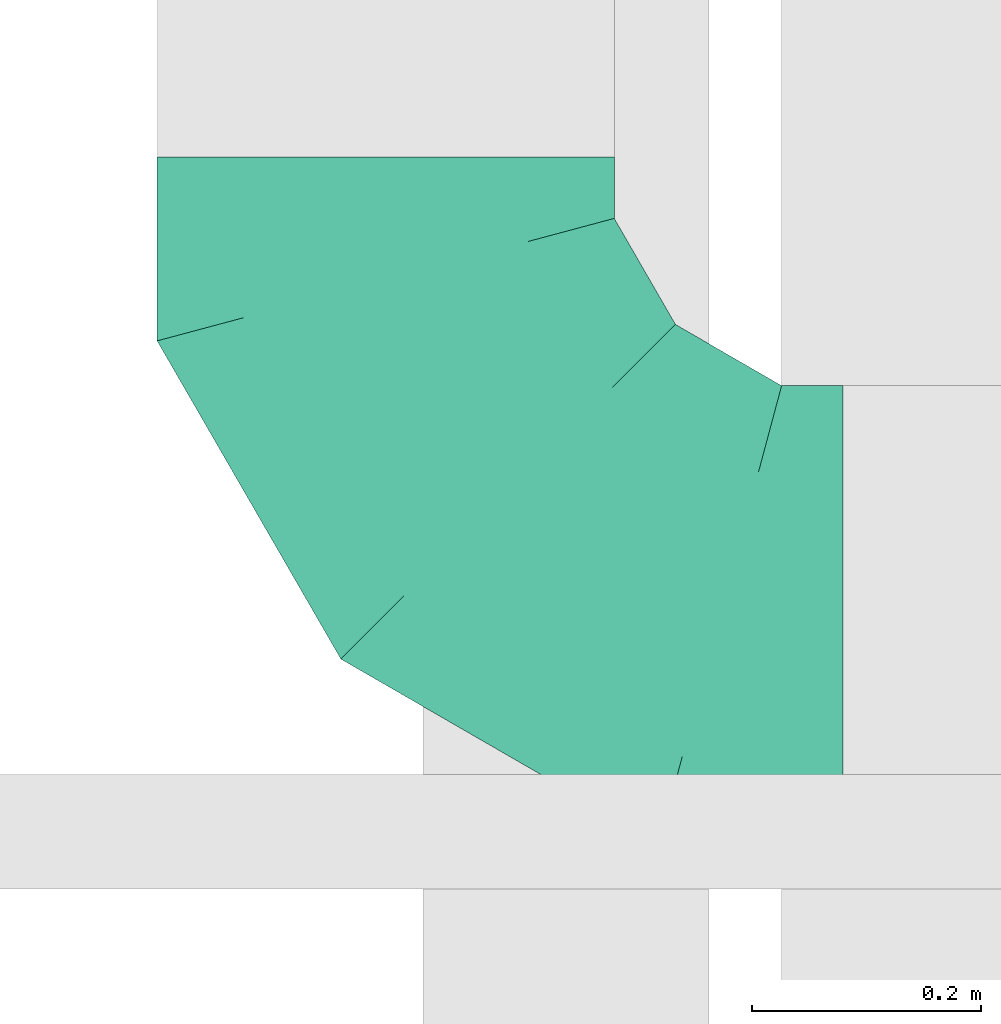
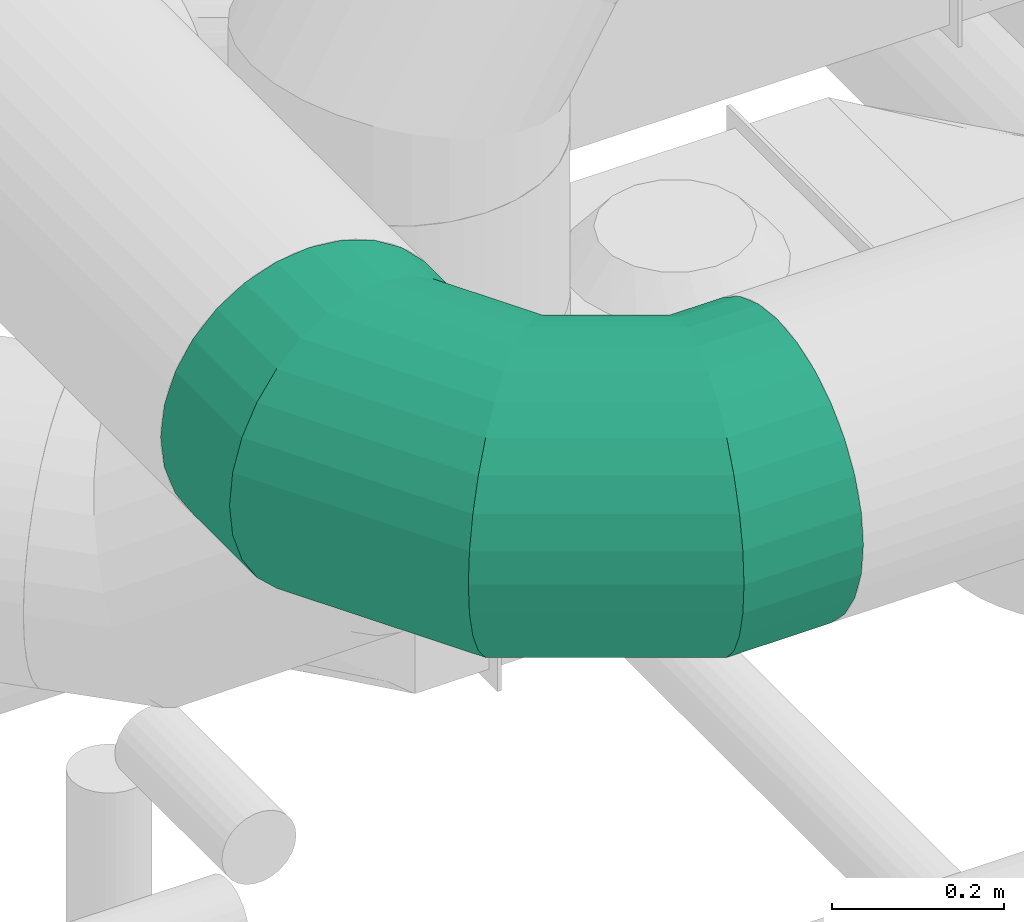
# One storey, part 217 of 337: 1 flow fitting.
"""IFC2X3 building model written with IfcOpenShell, lengths in millimetres."""

from ifc_helpers import new_model, entity, si_unit, converted_unit, derived_unit, direction, frame, origin, place, context, subcontext, project, spatial, faceted_brep, source, transform, mapped, material, type_object, type_shapes, element, save


model = new_model("IFC2X3")

# Units and contexts
model_context = context("Model", 3, precision=0.01, world=origin(), true_north=direction((6.12303176911189e-17, 1.0)))
body_context = subcontext(model_context, "Body", "Model", "MODEL_VIEW")
ifc_project = project(units=[si_unit("LENGTHUNIT", "METRE", prefix="MILLI"), si_unit("AREAUNIT", "SQUARE_METRE"), si_unit("VOLUMEUNIT", "CUBIC_METRE"), converted_unit("PLANEANGLEUNIT", "DEGREE", entity("IfcRatioMeasure", 0.0174532925199433), si_unit("PLANEANGLEUNIT", "RADIAN"), dimensions=[0, 0, 0, 0, 0, 0, 0]), si_unit("MASSUNIT", "GRAM", prefix="KILO"), derived_unit("MASSDENSITYUNIT", [(si_unit("MASSUNIT", "GRAM", prefix="KILO"), 1), (si_unit("LENGTHUNIT", "METRE"), -3)]), derived_unit("MOMENTOFINERTIAUNIT", [(si_unit("LENGTHUNIT", "METRE"), 4)]), si_unit("TIMEUNIT", "SECOND"), si_unit("FREQUENCYUNIT", "HERTZ"), si_unit("THERMODYNAMICTEMPERATUREUNIT", "DEGREE_CELSIUS"), derived_unit("THERMALTRANSMITTANCEUNIT", [(si_unit("MASSUNIT", "GRAM", prefix="KILO"), 1), (si_unit("THERMODYNAMICTEMPERATUREUNIT", "KELVIN"), -1), (si_unit("TIMEUNIT", "SECOND"), -3)]), derived_unit("VOLUMETRICFLOWRATEUNIT", [(si_unit("LENGTHUNIT", "METRE"), 3), (si_unit("TIMEUNIT", "SECOND"), -1)]), derived_unit("MASSFLOWRATEUNIT", [(si_unit("MASSUNIT", "GRAM", prefix="KILO"), 1), (si_unit("TIMEUNIT", "SECOND"), -1)]), derived_unit("ROTATIONALFREQUENCYUNIT", [(si_unit("TIMEUNIT", "SECOND"), -1)]), si_unit("ELECTRICCURRENTUNIT", "AMPERE"), si_unit("ELECTRICVOLTAGEUNIT", "VOLT"), si_unit("POWERUNIT", "WATT"), si_unit("FORCEUNIT", "NEWTON", prefix="KILO"), si_unit("ILLUMINANCEUNIT", "LUX"), si_unit("LUMINOUSFLUXUNIT", "LUMEN"), si_unit("LUMINOUSINTENSITYUNIT", "CANDELA"), derived_unit("USERDEFINED", [(si_unit("MASSUNIT", "GRAM", prefix="KILO"), -1), (si_unit("LENGTHUNIT", "METRE"), -2), (si_unit("TIMEUNIT", "SECOND"), 3), (si_unit("LUMINOUSFLUXUNIT", "LUMEN"), 1)]), derived_unit("LINEARVELOCITYUNIT", [(si_unit("LENGTHUNIT", "METRE"), 1), (si_unit("TIMEUNIT", "SECOND"), -1)]), si_unit("PRESSUREUNIT", "PASCAL"), derived_unit("USERDEFINED", [(si_unit("LENGTHUNIT", "METRE"), -2), (si_unit("MASSUNIT", "GRAM", prefix="KILO"), 1), (si_unit("TIMEUNIT", "SECOND"), -2)]), derived_unit("LINEARFORCEUNIT", [(si_unit("MASSUNIT", "GRAM", prefix="KILO"), 1), (si_unit("LENGTHUNIT", "METRE"), 1), (si_unit("TIMEUNIT", "SECOND"), -2), (si_unit("LENGTHUNIT", "METRE"), -1)]), derived_unit("PLANARFORCEUNIT", [(si_unit("MASSUNIT", "GRAM", prefix="KILO"), 1), (si_unit("LENGTHUNIT", "METRE"), 1), (si_unit("TIMEUNIT", "SECOND"), -2), (si_unit("LENGTHUNIT", "METRE"), -2)])], contexts=[model_context])

# Site, building, storey
site_placement = place(None, origin())
site = spatial("IfcSite", under=ifc_project, at=site_placement, CompositionType="ELEMENT")
building_placement = place(site_placement, origin())
building = spatial("IfcBuilding", under=site, at=building_placement, CompositionType="ELEMENT")
storey_placement = place(building_placement, origin())
storey = spatial("IfcBuildingStorey", under=building, at=storey_placement, CompositionType="ELEMENT", Elevation=0.0)

# Flow fitting
ifc_material = material()
duct_fitting_type = type_object("IfcDuctFittingType", PredefinedType="NOTDEFINED", material=ifc_material)
shared_shape = source(origin(), body_context, "Body", "Brep", [
    faceted_brep([(-400.0, 0.0, -200.0), (-400.0, -44.5, -194.99), (-400.0, -86.78, -180.19), (-400.0, -124.7, -156.37), (-400.0, -156.37, -124.7), (-400.0, -180.19, -86.78), (-400.0, -194.99, -44.5), (-400.0, -200.0, 0.0), (-400.0, -194.99, 44.5), (-400.0, -180.19, 86.78), (-400.0, -156.37, 124.7), (-400.0, -124.7, 156.37), (-400.0, -86.78, 180.19), (-400.0, -44.5, 194.99), (-400.0, 0.0, 200.0), (-400.0, 44.5, 194.99), (-400.0, 86.78, 180.19), (-400.0, 124.7, 156.37), (-400.0, 156.37, 124.7), (-400.0, 180.19, 86.78), (-400.0, 194.99, 44.5), (-400.0, 200.0, 0.0), (-400.0, 194.99, -44.5), (-400.0, 180.19, -86.78), (-400.0, 156.37, -124.7), (-400.0, 124.7, -156.37), (-400.0, 86.78, -180.19), (-400.0, 44.5, -194.99), (-292.82, 0.0, 200.0), (-304.75, 44.5, 194.99), (-316.07, 86.78, 180.19), (-326.23, 124.7, 156.37), (-334.72, 156.37, 124.7), (-341.1, 180.19, 86.78), (-345.07, 194.99, 44.5), (-346.41, 200.0, 0.0), (-345.07, 194.99, -44.5), (-341.1, 180.19, -86.78), (-334.72, 156.37, -124.7), (-326.23, 124.7, -156.37), (-316.07, 86.78, -180.19), (-304.75, 44.5, -194.99), (-292.82, 0.0, -200.0), (-280.9, -44.5, -194.99), (-269.57, -86.78, -180.19), (-259.41, -124.7, -156.37), (-250.92, -156.37, -124.7), (-244.54, -180.19, -86.78), (-240.57, -194.99, -44.5), (-239.23, -200.0, 0.0), (-240.57, -194.99, 44.5), (-244.54, -180.19, 86.78), (-250.92, -156.37, 124.7), (-259.41, -124.7, 156.37), (-269.57, -86.78, 180.19), (-280.9, -44.5, 194.99), (-107.18, 107.18, 200.0), (-139.76, 139.76, 194.99), (-170.7, 170.7, 180.19), (-198.46, 198.46, 156.37), (-221.65, 221.65, 124.7), (-239.09, 239.09, 86.78), (-249.92, 249.92, 44.5), (-253.59, 253.59, 0.0), (-249.92, 249.92, -44.5), (-239.09, 239.09, -86.78), (-221.65, 221.65, -124.7), (-198.46, 198.46, -156.37), (-170.7, 170.7, -180.19), (-139.76, 139.76, -194.99), (-107.18, 107.18, -200.0), (-74.6, 74.6, -194.99), (-43.65, 43.65, -180.19), (-15.89, 15.89, -156.37), (7.29, -7.29, -124.7), (24.73, -24.73, -86.78), (35.56, -35.56, -44.5), (39.23, -39.23, 0.0), (35.56, -35.56, 44.5), (24.73, -24.73, 86.78), (7.29, -7.29, 124.7), (-15.89, 15.89, 156.37), (-43.65, 43.65, 180.19), (-74.6, 74.6, 194.99), (0.0, 292.82, 200.0), (-44.5, 304.75, 194.99), (-86.78, 316.07, 180.19), (-124.7, 326.23, 156.37), (-156.37, 334.72, 124.7), (-180.19, 341.1, 86.78), (-194.99, 345.07, 44.5), (-200.0, 346.41, 0.0), (-194.99, 345.07, -44.5), (-180.19, 341.1, -86.78), (-156.37, 334.72, -124.7), (-124.7, 326.23, -156.37), (-86.78, 316.07, -180.19), (-44.5, 304.75, -194.99), (0.0, 292.82, -200.0), (44.5, 280.9, -194.99), (86.78, 269.57, -180.19), (124.7, 259.41, -156.37), (156.37, 250.92, -124.7), (180.19, 244.54, -86.78), (194.99, 240.57, -44.5), (200.0, 239.23, 0.0), (194.99, 240.57, 44.5), (180.19, 244.54, 86.78), (156.37, 250.92, 124.7), (124.7, 259.41, 156.37), (86.78, 269.57, 180.19), (44.5, 280.9, 194.99), (-44.5, 400.0, -194.99), (-86.78, 400.0, -180.19), (-124.7, 400.0, -156.37), (-156.37, 400.0, -124.7), (-180.19, 400.0, -86.78), (-194.99, 400.0, -44.5), (-200.0, 400.0, 0.0), (-194.99, 400.0, 44.5), (-180.19, 400.0, 86.78), (-156.37, 400.0, 124.7), (-124.7, 400.0, 156.37), (-86.78, 400.0, 180.19), (-44.5, 400.0, 194.99), (0.0, 400.0, 200.0), (44.5, 400.0, 194.99), (86.78, 400.0, 180.19), (124.7, 400.0, 156.37), (156.37, 400.0, 124.7), (180.19, 400.0, 86.78), (194.99, 400.0, 44.5), (200.0, 400.0, 0.0), (194.99, 400.0, -44.5), (180.19, 400.0, -86.78), (156.37, 400.0, -124.7), (124.7, 400.0, -156.37), (86.78, 400.0, -180.19), (44.5, 400.0, -194.99), (0.0, 400.0, -200.0)], [[[0, 1, 2, 3, 4, 5, 6, 7, 8, 9, 10, 11, 12, 13, 14, 15, 16, 17, 18, 19, 20, 21, 22, 23, 24, 25, 26, 27]], [[28, 29, 15, 14]], [[30, 31, 17, 16]], [[29, 30, 16, 15]], [[31, 32, 18, 17]], [[32, 33, 19, 18]], [[34, 35, 21, 20]], [[33, 34, 20, 19]], [[35, 36, 22, 21]], [[37, 38, 24, 23]], [[36, 37, 23, 22]], [[38, 39, 25, 24]], [[39, 40, 26, 25]], [[41, 42, 0, 27]], [[40, 41, 27, 26]], [[1, 0, 42, 43]], [[43, 44, 2, 1]], [[45, 3, 2, 44]], [[45, 46, 4, 3]], [[5, 4, 46, 47]], [[47, 48, 6, 5]], [[49, 7, 6, 48]], [[7, 49, 50, 8]], [[8, 50, 51, 9]], [[9, 51, 52, 10]], [[52, 53, 11, 10]], [[11, 53, 54, 12]], [[12, 54, 55, 13]], [[13, 55, 28, 14]], [[56, 57, 29, 28]], [[58, 59, 31, 30]], [[57, 58, 30, 29]], [[59, 60, 32, 31]], [[60, 61, 33, 32]], [[62, 63, 35, 34]], [[61, 62, 34, 33]], [[63, 64, 36, 35]], [[65, 66, 38, 37]], [[64, 65, 37, 36]], [[66, 67, 39, 38]], [[67, 68, 40, 39]], [[69, 70, 42, 41]], [[68, 69, 41, 40]], [[43, 42, 70, 71]], [[71, 72, 44, 43]], [[73, 45, 44, 72]], [[73, 74, 46, 45]], [[47, 46, 74, 75]], [[75, 76, 48, 47]], [[77, 49, 48, 76]], [[50, 49, 77, 78]], [[51, 50, 78, 79]], [[52, 51, 79, 80]], [[80, 81, 53, 52]], [[54, 53, 81, 82]], [[55, 54, 82, 83]], [[28, 55, 83, 56]], [[84, 85, 57, 56]], [[86, 87, 59, 58]], [[85, 86, 58, 57]], [[87, 88, 60, 59]], [[88, 89, 61, 60]], [[90, 91, 63, 62]], [[89, 90, 62, 61]], [[91, 92, 64, 63]], [[93, 94, 66, 65]], [[92, 93, 65, 64]], [[94, 95, 67, 66]], [[95, 96, 68, 67]], [[97, 98, 70, 69]], [[96, 97, 69, 68]], [[71, 70, 98, 99]], [[99, 100, 72, 71]], [[101, 73, 72, 100]], [[101, 102, 74, 73]], [[75, 74, 102, 103]], [[103, 104, 76, 75]], [[105, 77, 76, 104]], [[78, 77, 105, 106]], [[79, 78, 106, 107]], [[80, 79, 107, 108]], [[108, 109, 81, 80]], [[82, 81, 109, 110]], [[83, 82, 110, 111]], [[56, 83, 111, 84]], [[112, 113, 114, 115, 116, 117, 118, 119, 120, 121, 122, 123, 124, 125, 126, 127, 128, 129, 130, 131, 132, 133, 134, 135, 136, 137, 138, 139]], [[85, 84, 125, 124]], [[86, 85, 124, 123]], [[87, 86, 123, 122]], [[122, 121, 88, 87]], [[89, 88, 121, 120]], [[90, 89, 120, 119]], [[91, 90, 119, 118]], [[91, 118, 117, 92]], [[92, 117, 116, 93]], [[93, 116, 115, 94]], [[115, 114, 95, 94]], [[95, 114, 113, 96]], [[96, 113, 112, 97]], [[97, 112, 139, 98]], [[98, 139, 138, 99]], [[99, 138, 137, 100]], [[100, 137, 136, 101]], [[136, 135, 102, 101]], [[102, 135, 134, 103]], [[103, 134, 133, 104]], [[104, 133, 132, 105]], [[106, 105, 132, 131]], [[107, 106, 131, 130]], [[108, 107, 130, 129]], [[129, 128, 109, 108]], [[110, 109, 128, 127]], [[111, 110, 127, 126]], [[84, 111, 126, 125]]]),
])
type_shapes(duct_fitting_type, [shared_shape])
flow_fitting_placement = place(storey_placement, frame((67559.05, 6453.72, 35550.0), z_axis=(0.0, 0.0, 1.0), x_axis=(0.0, -1.0, 0.0)))
element("IfcFlowFitting", 1, at=flow_fitting_placement, inside=storey, type_object=duct_fitting_type, material=ifc_material, context=body_context, shape_type="MappedRepresentation", body=[
    mapped(shared_shape, transform((0.0, 0.0, 0.0), scale=1.0)),
])

save(model, "model.ifc")
